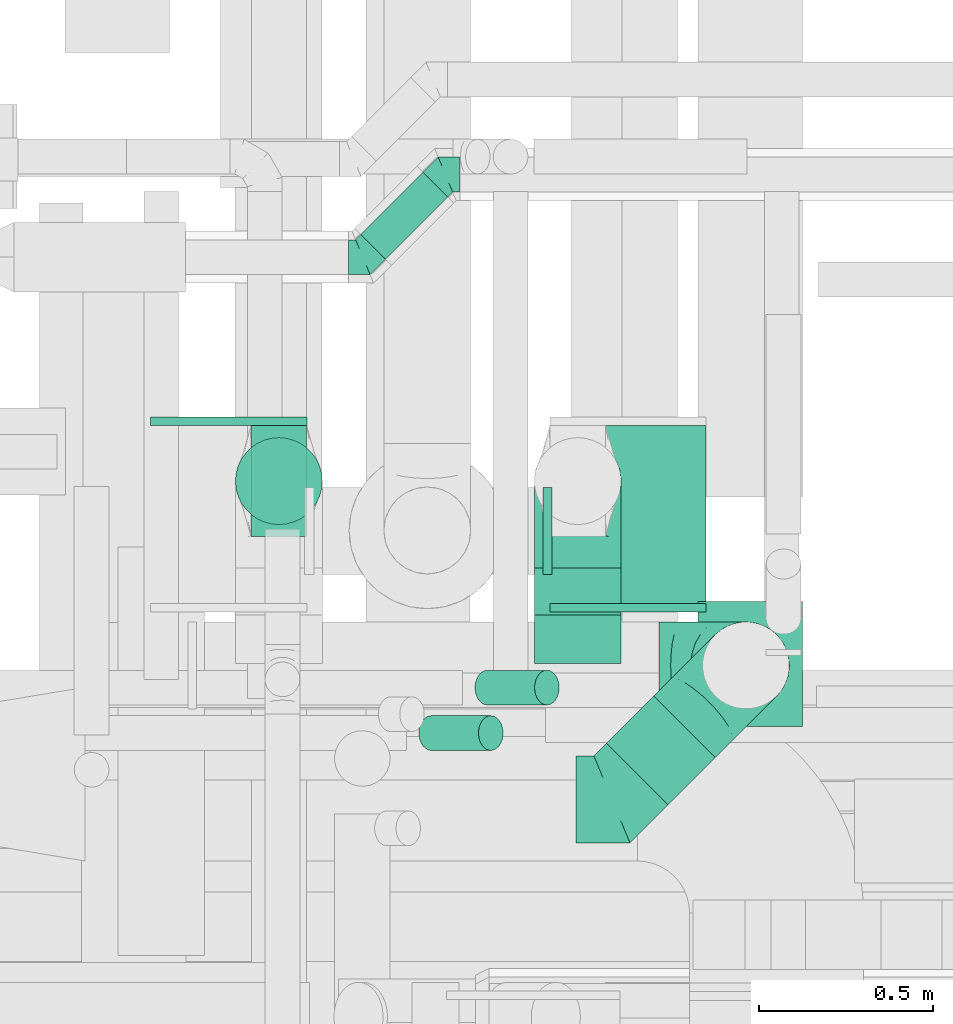
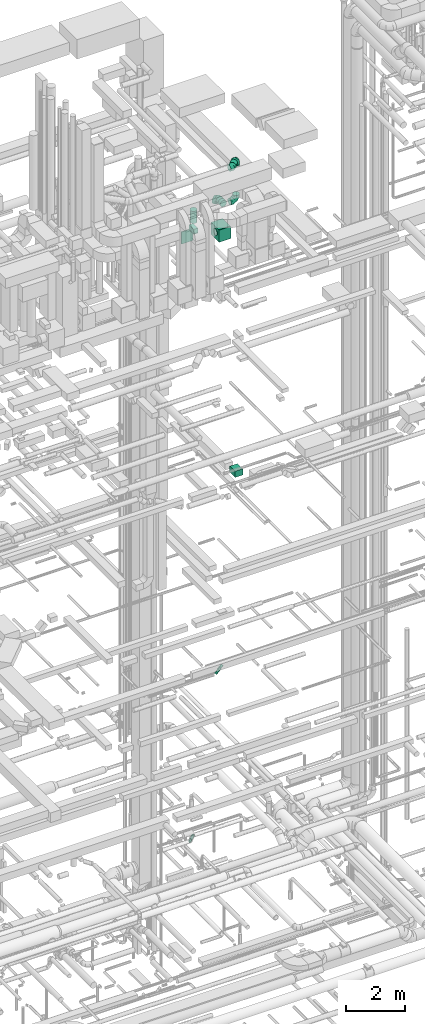
# One storey, part 242 of 337: 11 flow fittings, 9 flow segments.
"""IFC2X3 building model written with IfcOpenShell, lengths in millimetres."""

from ifc_helpers import new_model, entity, si_unit, converted_unit, derived_unit, direction, frame, origin, origin_2d_with_axis, place, context, subcontext, project, spatial, rectangle, circle, extrude, faceted_brep, source, transform, mapped, material, type_object, type_shapes, element, save


model = new_model("IFC2X3")

# Units and contexts
model_context = context("Model", 3, precision=0.01, world=origin(), true_north=direction((6.12303176911189e-17, 1.0)))
body_context = subcontext(model_context, "Body", "Model", "MODEL_VIEW")
ifc_project = project(units=[si_unit("LENGTHUNIT", "METRE", prefix="MILLI"), si_unit("AREAUNIT", "SQUARE_METRE"), si_unit("VOLUMEUNIT", "CUBIC_METRE"), converted_unit("PLANEANGLEUNIT", "DEGREE", entity("IfcRatioMeasure", 0.0174532925199433), si_unit("PLANEANGLEUNIT", "RADIAN"), dimensions=[0, 0, 0, 0, 0, 0, 0]), si_unit("MASSUNIT", "GRAM", prefix="KILO"), derived_unit("MASSDENSITYUNIT", [(si_unit("MASSUNIT", "GRAM", prefix="KILO"), 1), (si_unit("LENGTHUNIT", "METRE"), -3)]), derived_unit("MOMENTOFINERTIAUNIT", [(si_unit("LENGTHUNIT", "METRE"), 4)]), si_unit("TIMEUNIT", "SECOND"), si_unit("FREQUENCYUNIT", "HERTZ"), si_unit("THERMODYNAMICTEMPERATUREUNIT", "DEGREE_CELSIUS"), derived_unit("THERMALTRANSMITTANCEUNIT", [(si_unit("MASSUNIT", "GRAM", prefix="KILO"), 1), (si_unit("THERMODYNAMICTEMPERATUREUNIT", "KELVIN"), -1), (si_unit("TIMEUNIT", "SECOND"), -3)]), derived_unit("VOLUMETRICFLOWRATEUNIT", [(si_unit("LENGTHUNIT", "METRE"), 3), (si_unit("TIMEUNIT", "SECOND"), -1)]), derived_unit("MASSFLOWRATEUNIT", [(si_unit("MASSUNIT", "GRAM", prefix="KILO"), 1), (si_unit("TIMEUNIT", "SECOND"), -1)]), derived_unit("ROTATIONALFREQUENCYUNIT", [(si_unit("TIMEUNIT", "SECOND"), -1)]), si_unit("ELECTRICCURRENTUNIT", "AMPERE"), si_unit("ELECTRICVOLTAGEUNIT", "VOLT"), si_unit("POWERUNIT", "WATT"), si_unit("FORCEUNIT", "NEWTON", prefix="KILO"), si_unit("ILLUMINANCEUNIT", "LUX"), si_unit("LUMINOUSFLUXUNIT", "LUMEN"), si_unit("LUMINOUSINTENSITYUNIT", "CANDELA"), derived_unit("USERDEFINED", [(si_unit("MASSUNIT", "GRAM", prefix="KILO"), -1), (si_unit("LENGTHUNIT", "METRE"), -2), (si_unit("TIMEUNIT", "SECOND"), 3), (si_unit("LUMINOUSFLUXUNIT", "LUMEN"), 1)]), derived_unit("LINEARVELOCITYUNIT", [(si_unit("LENGTHUNIT", "METRE"), 1), (si_unit("TIMEUNIT", "SECOND"), -1)]), si_unit("PRESSUREUNIT", "PASCAL"), derived_unit("USERDEFINED", [(si_unit("LENGTHUNIT", "METRE"), -2), (si_unit("MASSUNIT", "GRAM", prefix="KILO"), 1), (si_unit("TIMEUNIT", "SECOND"), -2)]), derived_unit("LINEARFORCEUNIT", [(si_unit("MASSUNIT", "GRAM", prefix="KILO"), 1), (si_unit("LENGTHUNIT", "METRE"), 1), (si_unit("TIMEUNIT", "SECOND"), -2), (si_unit("LENGTHUNIT", "METRE"), -1)]), derived_unit("PLANARFORCEUNIT", [(si_unit("MASSUNIT", "GRAM", prefix="KILO"), 1), (si_unit("LENGTHUNIT", "METRE"), 1), (si_unit("TIMEUNIT", "SECOND"), -2), (si_unit("LENGTHUNIT", "METRE"), -2)])], contexts=[model_context])

# Site, building, storey
site_placement = place(None, origin())
site = spatial("IfcSite", under=ifc_project, at=site_placement, CompositionType="ELEMENT")
building_placement = place(site_placement, origin())
building = spatial("IfcBuilding", under=site, at=building_placement, CompositionType="ELEMENT")
storey_placement = place(building_placement, origin())
storey = spatial("IfcBuildingStorey", under=building, at=storey_placement, CompositionType="ELEMENT", Elevation=0.0)

# Flow segments
duct_segment_type_1 = type_object("IfcDuctSegmentType", PredefinedType="NOTDEFINED")
flow_segment_1_placement = place(storey_placement, frame((61894.65, 10174.07, 18850.0)))
element("IfcFlowSegment", 1, at=flow_segment_1_placement, inside=storey, type_object=duct_segment_type_1, context=body_context, shape_type="SweptSolid", body=[
    extrude(rectangle(XDim=360.158729652658, YDim=300.000000000001, at=origin_2d_with_axis()), frame((150.0, 180.08, 0.0), z_axis=(0.0, 0.0, 1.0), x_axis=(0.0, 1.0, 0.0)), (0.0, 0.0, 1.0), 249.999999999999),
])
flow_segment_2_placement = place(storey_placement, frame((61467.66, 10528.49, 28450.0)))
element("IfcFlowSegment", 2, at=flow_segment_2_placement, inside=storey, type_object=duct_segment_type_1, context=body_context, shape_type="SweptSolid", body=[
    extrude(rectangle(XDim=512.000000000001, YDim=450.000000000002, at=origin_2d_with_axis()), frame((225.0, 256.0, 0.0), z_axis=(0.0, 0.0, 1.0), x_axis=(0.0, 1.0, 0.0)), (0.0, 0.0, 1.0), 499.999999999999),
])
flow_segment_3_placement = place(storey_placement, frame((60608.16, 10720.49, 28970.0)))
element("IfcFlowSegment", 3, at=flow_segment_3_placement, inside=storey, type_object=duct_segment_type_1, context=body_context, shape_type="SweptSolid", body=[
    extrude(rectangle(XDim=320.000000000003, YDim=159.999999999998, at=origin_2d_with_axis()), frame((80.0, 160.0, 0.0), z_axis=(0.0, 0.0, 1.0), x_axis=(0.0, -1.0, 0.0)), (0.0, 0.0, 1.0), 180.000000000002),
])
duct_segment_type_2 = type_object("IfcDuctSegmentType", PredefinedType="NOTDEFINED")
flow_segment_4_placement = place(storey_placement, frame((60922.1, 11517.23, 3398.4)))
element("IfcFlowSegment", 4, at=flow_segment_4_placement, inside=storey, type_object=duct_segment_type_2, context=body_context, shape_type="SweptSolid", body=[
    extrude(circle(Radius=50.0, at=origin_2d_with_axis()), frame((36.95, 36.95, 51.6), z_axis=(0.707106781186415, 0.70710678118668, 0.0), x_axis=(0.70710678118668, -0.707106781186415, 0.0)), (0.0, 0.0, 1.0), 253.309524416838),
])
flow_segment_5_placement = place(storey_placement, frame((61250.98, 10234.73, 11042.34)))
element("IfcFlowSegment", 5, at=flow_segment_5_placement, inside=storey, type_object=duct_segment_type_2, context=body_context, shape_type="SweptSolid", body=[
    extrude(circle(Radius=50.0, at=origin_2d_with_axis()), frame((36.95, 51.6, 36.95), z_axis=(0.707106523092446, 0.0, 0.707107039280555), x_axis=(0.0, 1.0, 0.0)), (0.0, 0.0, 1.0), 242.426245385358),
])
flow_segment_6_placement = place(storey_placement, frame((61089.62, 10104.0, 11042.34)))
element("IfcFlowSegment", 6, at=flow_segment_6_placement, inside=storey, type_object=duct_segment_type_2, context=body_context, shape_type="SweptSolid", body=[
    extrude(circle(Radius=50.0, at=origin_2d_with_axis()), frame((36.95, 51.6, 36.95), z_axis=(0.707106523092436, 0.0, 0.707107039280565), x_axis=(0.0, 1.0, 0.0)), (0.0, 0.0, 1.0), 242.426245385361),
])
flow_segment_7_placement = place(storey_placement, frame((61629.76, 9947.97, 31673.4)))
element("IfcFlowSegment", 7, at=flow_segment_7_placement, inside=storey, type_object=duct_segment_type_2, context=body_context, shape_type="SweptSolid", body=[
    extrude(circle(Radius=125.0, at=origin_2d_with_axis()), frame((89.98, 89.98, 126.6), z_axis=(0.707106781186559, 0.707106781186536, 0.0), x_axis=(0.707106781186536, -0.707106781186559, 0.0)), (0.0, 0.0, 1.0), 191.560539722336),
])
flow_segment_8_placement = place(storey_placement, frame((61421.56, 10495.19, 29973.4)))
element("IfcFlowSegment", 8, at=flow_segment_8_placement, inside=storey, type_object=duct_segment_type_2, context=body_context, shape_type="SweptSolid", body=[
    extrude(circle(Radius=125.0, at=origin_2d_with_axis()), frame((126.6, 0.0, 126.6), z_axis=(0.0, 1.0, 0.0), x_axis=(1.0, 0.0, 0.0)), (0.0, 0.0, 1.0), 135.302523354552),
])
flow_segment_9_placement = place(storey_placement, frame((60561.56, 10753.89, 29350.0)))
element("IfcFlowSegment", 9, at=flow_segment_9_placement, inside=storey, type_object=duct_segment_type_2, context=body_context, shape_type="SweptSolid", body=[
    extrude(circle(Radius=125.0, at=origin_2d_with_axis()), frame((126.6, 126.6, 0.0), z_axis=(0.0, 0.0, 1.0), x_axis=(-1.0, 0.0, 0.0)), (0.0, 0.0, 1.0), 500.000000000008),
])

# Flow fittings
ifc_material = material()
duct_fitting_type_1 = type_object("IfcDuctFittingType", PredefinedType="NOTDEFINED", material=ifc_material)
shared_shape_1 = source(origin(), body_context, "Body", "SweptSolid", [
    extrude(rectangle(XDim=24.9999999999999, YDim=450.0, at=origin_2d_with_axis()), frame((12.5, 0.0, -250.0)), (0.0, 0.0, 1.0), 500.0),
])
type_shapes(duct_fitting_type_1, [shared_shape_1])
for number, where, z_axis, x_axis in (
    (10, (61692.66, 10528.49, 28700.0), (0.0, 0.0, 1.0), (0.0, -1.0, 0.0)),
    (11, (60543.66, 11040.49, 28700.0), (0.0, 0.0, 1.0), (0.0, 1.0, 0.0)),
):
    element("IfcFlowFitting", number, at=place(storey_placement, frame(where, z_axis=z_axis, x_axis=x_axis)), inside=storey, type_object=duct_fitting_type_1, material=ifc_material, context=body_context, shape_type="MappedRepresentation", body=[
        mapped(shared_shape_1, transform((0.0, 0.0, 0.0), scale=1.0)),
    ])
duct_fitting_type_2 = type_object("IfcDuctFittingType", PredefinedType="NOTDEFINED", material=ifc_material)
shared_shape_2 = source(origin(), body_context, "Body", "SweptSolid", [
    extrude(rectangle(XDim=160.0, YDim=26.096, at=origin_2d_with_axis()), frame((6.95, 0.0, -160.0), z_axis=(0.0, 0.0, 1.0), x_axis=(0.0, -1.0, 0.0)), (0.0, 0.0, 1.0), 320.0),
])
type_shapes(duct_fitting_type_2, [shared_shape_2])
flow_fitting_1_placement = place(storey_placement, frame((60688.16, 10880.49, 28950.0), z_axis=(0.0, -1.0, 0.0), x_axis=(0.0, 0.0, 1.0)))
element("IfcFlowFitting", 12, at=flow_fitting_1_placement, inside=storey, type_object=duct_fitting_type_2, material=ifc_material, context=body_context, shape_type="MappedRepresentation", body=[
    mapped(shared_shape_2, transform((0.0, 0.0, 0.0), scale=1.0)),
])
duct_fitting_type_3 = type_object("IfcDuctFittingType", PredefinedType="NOTDEFINED", material=ifc_material)
shared_shape_3 = source(origin(), body_context, "Body", "Brep", [
    faceted_brep([(-250.0, 0.0, -125.0), (-250.0, -32.35, -120.74), (-250.0, -62.5, -108.25), (-250.0, -88.39, -88.39), (-250.0, -108.25, -62.5), (-250.0, -120.74, -32.35), (-250.0, -125.0, 0.0), (-250.0, -120.74, 32.35), (-250.0, -108.25, 62.5), (-250.0, -88.39, 88.39), (-250.0, -62.5, 108.25), (-250.0, -32.35, 120.74), (-250.0, 0.0, 125.0), (-250.0, 32.35, 120.74), (-250.0, 62.5, 108.25), (-250.0, 88.39, 88.39), (-250.0, 108.25, 62.5), (-250.0, 120.74, 32.35), (-250.0, 125.0, 0.0), (-250.0, 120.74, -32.35), (-250.0, 108.25, -62.5), (-250.0, 88.39, -88.39), (-250.0, 62.5, -108.25), (-250.0, 32.35, -120.74), (-191.68, 32.35, 120.74), (-199.76, 62.5, 108.25), (-183.01, 0.0, 125.0), (-206.7, 88.39, 88.39), (-215.37, 120.74, 32.35), (-216.51, 125.0, 0.0), (-212.02, 108.25, 62.5), (-212.02, 108.25, -62.5), (-206.7, 88.39, -88.39), (-215.37, 120.74, -32.35), (-191.68, 32.35, -120.74), (-183.01, 0.0, -125.0), (-199.76, 62.5, -108.25), (-174.34, -32.35, -120.74), (-166.27, -62.5, -108.25), (-159.33, -88.39, -88.39), (-154.01, -108.25, -62.5), (-150.66, -120.74, -32.35), (-149.52, -125.0, 0.0), (-150.66, -120.74, 32.35), (-154.01, -108.25, 62.5), (-159.33, -88.39, 88.39), (-166.27, -62.5, 108.25), (-174.34, -32.35, 120.74), (-90.67, 90.67, 120.74), (-112.74, 112.74, 108.25), (-66.99, 66.99, 125.0), (-131.69, 131.69, 88.39), (-146.23, 146.23, 62.5), (-155.38, 155.38, 32.35), (-158.49, 158.49, 0.0), (-155.38, 155.38, -32.35), (-146.23, 146.23, -62.5), (-131.69, 131.69, -88.39), (-90.67, 90.67, -120.74), (-66.99, 66.99, -125.0), (-112.74, 112.74, -108.25), (-43.3, 43.3, -120.74), (-21.23, 21.23, -108.25), (-2.28, 2.28, -88.39), (12.26, -12.26, -62.5), (21.4, -21.4, -32.35), (24.52, -24.52, 0.0), (21.4, -21.4, 32.35), (12.26, -12.26, 62.5), (-2.28, 2.28, 88.39), (-21.23, 21.23, 108.25), (-43.3, 43.3, 120.74), (-32.35, 191.68, 120.74), (-62.5, 199.76, 108.25), (0.0, 183.01, 125.0), (-88.39, 206.7, 88.39), (-108.25, 212.02, 62.5), (-120.74, 215.37, 32.35), (-125.0, 216.51, 0.0), (-120.74, 215.37, -32.35), (-108.25, 212.02, -62.5), (-88.39, 206.7, -88.39), (-32.35, 191.68, -120.74), (0.0, 183.01, -125.0), (-62.5, 199.76, -108.25), (32.35, 174.34, -120.74), (62.5, 166.27, -108.25), (88.39, 159.33, -88.39), (108.25, 154.01, -62.5), (120.74, 150.66, -32.35), (125.0, 149.52, 0.0), (120.74, 150.66, 32.35), (108.25, 154.01, 62.5), (88.39, 159.33, 88.39), (62.5, 166.27, 108.25), (32.35, 174.34, 120.74), (-32.35, 250.0, -120.74), (-62.5, 250.0, -108.25), (-88.39, 250.0, -88.39), (-108.25, 250.0, -62.5), (-120.74, 250.0, -32.35), (-125.0, 250.0, 0.0), (-120.74, 250.0, 32.35), (-108.25, 250.0, 62.5), (-88.39, 250.0, 88.39), (-62.5, 250.0, 108.25), (-32.35, 250.0, 120.74), (0.0, 250.0, 125.0), (32.35, 250.0, 120.74), (62.5, 250.0, 108.25), (88.39, 250.0, 88.39), (108.25, 250.0, 62.5), (120.74, 250.0, 32.35), (125.0, 250.0, 0.0), (120.74, 250.0, -32.35), (108.25, 250.0, -62.5), (88.39, 250.0, -88.39), (62.5, 250.0, -108.25), (32.35, 250.0, -120.74), (0.0, 250.0, -125.0)], [[[0, 1, 2, 3, 4, 5, 6, 7, 8, 9, 10, 11, 12, 13, 14, 15, 16, 17, 18, 19, 20, 21, 22, 23]], [[24, 25, 14, 13]], [[26, 24, 13, 12]], [[14, 25, 27, 15]], [[28, 29, 18, 17]], [[30, 28, 17, 16]], [[15, 27, 30, 16]], [[20, 31, 32, 21]], [[33, 31, 20, 19]], [[18, 29, 33, 19]], [[34, 35, 0, 23]], [[36, 34, 23, 22]], [[21, 32, 36, 22]], [[1, 0, 35, 37]], [[2, 1, 37, 38]], [[38, 39, 3, 2]], [[5, 4, 40, 41]], [[6, 5, 41, 42]], [[39, 40, 4, 3]], [[6, 42, 43, 7]], [[7, 43, 44, 8]], [[8, 44, 45, 9]], [[9, 45, 46, 10]], [[10, 46, 47, 11]], [[26, 12, 11, 47]], [[48, 49, 25, 24]], [[50, 48, 24, 26]], [[27, 25, 49, 51]], [[52, 53, 28, 30]], [[51, 52, 30, 27]], [[29, 28, 53, 54]], [[55, 56, 31, 33]], [[54, 55, 33, 29]], [[32, 31, 56, 57]], [[58, 59, 35, 34]], [[60, 58, 34, 36]], [[57, 60, 36, 32]], [[37, 35, 59, 61]], [[38, 37, 61, 62]], [[39, 38, 62, 63]], [[41, 40, 64, 65]], [[42, 41, 65, 66]], [[63, 64, 40, 39]], [[43, 42, 66, 67]], [[44, 43, 67, 68]], [[68, 69, 45, 44]], [[46, 45, 69, 70]], [[47, 46, 70, 71]], [[26, 47, 71, 50]], [[72, 73, 49, 48]], [[74, 72, 48, 50]], [[51, 49, 73, 75]], [[76, 77, 53, 52]], [[75, 76, 52, 51]], [[54, 53, 77, 78]], [[79, 80, 56, 55]], [[78, 79, 55, 54]], [[57, 56, 80, 81]], [[82, 83, 59, 58]], [[84, 82, 58, 60]], [[81, 84, 60, 57]], [[61, 59, 83, 85]], [[62, 61, 85, 86]], [[63, 62, 86, 87]], [[65, 64, 88, 89]], [[66, 65, 89, 90]], [[87, 88, 64, 63]], [[67, 66, 90, 91]], [[68, 67, 91, 92]], [[92, 93, 69, 68]], [[70, 69, 93, 94]], [[71, 70, 94, 95]], [[50, 71, 95, 74]], [[96, 97, 98, 99, 100, 101, 102, 103, 104, 105, 106, 107, 108, 109, 110, 111, 112, 113, 114, 115, 116, 117, 118, 119]], [[72, 74, 107, 106]], [[73, 72, 106, 105]], [[75, 73, 105, 104]], [[77, 76, 103, 102]], [[78, 77, 102, 101]], [[75, 104, 103, 76]], [[78, 101, 100, 79]], [[79, 100, 99, 80]], [[80, 99, 98, 81]], [[84, 97, 96, 82]], [[82, 96, 119, 83]], [[84, 81, 98, 97]], [[83, 119, 118, 85]], [[85, 118, 117, 86]], [[116, 87, 86, 117]], [[88, 115, 114, 89]], [[89, 114, 113, 90]], [[115, 88, 87, 116]], [[91, 90, 113, 112]], [[92, 91, 112, 111]], [[111, 110, 93, 92]], [[95, 94, 109, 108]], [[74, 95, 108, 107]], [[110, 109, 94, 93]]]),
])
type_shapes(duct_fitting_type_3, [shared_shape_3])
for number, where, z_axis, x_axis in (
    (13, (62031.97, 10350.19, 31800.0), (-0.707106781186555, 0.70710678118654, 0.0), (0.70710678118654, 0.707106781186555, 0.0)),
    (14, (62031.97, 10350.19, 30100.0), (0.0, 1.0, 0.0), (0.0, 0.0, -1.0)),
    (15, (61548.16, 10880.49, 30100.0), (-1.0, 0.0, 0.0), (0.0, 1.0, 0.0)),
):
    element("IfcFlowFitting", number, at=place(storey_placement, frame(where, z_axis=z_axis, x_axis=x_axis)), inside=storey, type_object=duct_fitting_type_3, material=ifc_material, context=body_context, shape_type="MappedRepresentation", body=[
        mapped(shared_shape_3, transform((0.0, 0.0, 0.0), scale=1.0)),
    ])
duct_fitting_type_4 = type_object("IfcDuctFittingType", PredefinedType="NOTDEFINED", material=ifc_material)
shared_shape_4 = source(origin(), body_context, "Body", "Brep", [
    faceted_brep([(20.0, 32.35, -120.74), (20.0, 62.5, -108.25), (20.0, 88.39, -88.39), (20.0, 108.25, -62.5), (20.0, 120.74, -32.35), (20.0, 125.0, 0.0), (20.0, 120.74, 32.35), (20.0, 108.25, 62.5), (20.0, 88.39, 88.39), (20.0, 62.5, 108.25), (20.0, 32.35, 120.74), (20.0, 0.0, 125.0), (20.0, -32.35, 120.74), (20.0, -62.5, 108.25), (20.0, -88.39, 88.39), (20.0, -108.25, 62.5), (20.0, -120.74, 32.35), (20.0, -125.0, 0.0), (20.0, -120.74, -32.35), (20.0, -108.25, -62.5), (20.0, -88.39, -88.39), (20.0, -62.5, -108.25), (20.0, -32.35, -120.74), (20.0, 0.0, -125.0), (0.0, 0.0, 125.0), (0.0, 32.35, 120.74), (-6.1, 32.35, 120.74), (-6.1, 0.0, 125.0), (0.0, 62.5, 108.25), (-6.1, 62.5, 108.25), (0.0, 88.39, 88.39), (-6.1, 88.39, 88.39), (0.0, 108.25, 62.5), (0.0, 120.74, 32.35), (-6.1, 120.74, 32.35), (-6.1, 108.25, 62.5), (0.0, 125.0, 0.0), (-6.1, 125.0, 0.0), (0.0, 120.74, -32.35), (-6.1, 120.74, -32.35), (0.0, 108.25, -62.5), (-6.1, 108.25, -62.5), (0.0, 88.39, -88.39), (-6.1, 88.39, -88.39), (0.0, 62.5, -108.25), (0.0, 32.35, -120.74), (-6.1, 32.35, -120.74), (-6.1, 62.5, -108.25), (0.0, 0.0, -125.0), (-6.1, 0.0, -125.0), (0.0, -32.35, -120.74), (-6.1, -32.35, -120.74), (0.0, -62.5, -108.25), (-6.1, -62.5, -108.25), (0.0, -88.39, -88.39), (-6.1, -88.39, -88.39), (0.0, -108.25, -62.5), (0.0, -120.74, -32.35), (-6.1, -120.74, -32.35), (-6.1, -108.25, -62.5), (0.0, -125.0, 0.0), (-6.1, -125.0, 0.0), (0.0, -120.74, 32.35), (-6.1, -120.74, 32.35), (0.0, -108.25, 62.5), (-6.1, -108.25, 62.5), (0.0, -88.39, 88.39), (-6.1, -88.39, 88.39), (0.0, -62.5, 108.25), (0.0, -32.35, 120.74), (-6.1, -32.35, 120.74), (-6.1, -62.5, 108.25)], [[[0, 1, 2, 3, 4, 5, 6, 7, 8, 9, 10, 11, 12, 13, 14, 15, 16, 17, 18, 19, 20, 21, 22, 23]], [[24, 11, 10, 25, 26, 27]], [[25, 10, 9, 28, 29, 26]], [[28, 9, 8, 30, 31, 29]], [[32, 7, 6, 33, 34, 35]], [[33, 6, 5, 36, 37, 34]], [[30, 8, 7, 32, 35, 31]], [[36, 5, 4, 38, 39, 37]], [[38, 4, 3, 40, 41, 39]], [[40, 3, 2, 42, 43, 41]], [[44, 1, 0, 45, 46, 47]], [[45, 0, 23, 48, 49, 46]], [[42, 2, 1, 44, 47, 43]], [[48, 23, 22, 50, 51, 49]], [[50, 22, 21, 52, 53, 51]], [[52, 21, 20, 54, 55, 53]], [[56, 19, 18, 57, 58, 59]], [[57, 18, 17, 60, 61, 58]], [[54, 20, 19, 56, 59, 55]], [[60, 17, 16, 62, 63, 61]], [[62, 16, 15, 64, 65, 63]], [[64, 15, 14, 66, 67, 65]], [[68, 13, 12, 69, 70, 71]], [[69, 12, 11, 24, 27, 70]], [[66, 14, 13, 68, 71, 67]], [[49, 51, 53, 55, 59, 58, 61, 63, 65, 67, 71, 70, 27, 26, 29, 31, 35, 34, 37, 39, 41, 43, 47, 46]]]),
])
type_shapes(duct_fitting_type_4, [shared_shape_4])
flow_fitting_2_placement = place(storey_placement, frame((61467.66, 10737.49, 28740.0), z_axis=(0.0, 0.0, -1.0), x_axis=(-1.0, 0.0, 0.0)))
element("IfcFlowFitting", 16, at=flow_fitting_2_placement, inside=storey, type_object=duct_fitting_type_4, material=ifc_material, context=body_context, shape_type="MappedRepresentation", body=[
    mapped(shared_shape_4, transform((0.0, 0.0, 0.0), scale=1.0)),
])
duct_fitting_type_5 = type_object("IfcDuctFittingType", PredefinedType="NOTDEFINED", material=ifc_material)
shared_shape_5 = source(origin(), body_context, "Body", "Brep", [
    faceted_brep([(-41.42, 0.0, -50.0), (-41.42, -12.94, -48.3), (-41.42, -25.0, -43.3), (-41.42, -35.36, -35.36), (-41.42, -43.3, -25.0), (-41.42, -48.3, -12.94), (-41.42, -50.0, 0.0), (-41.42, -48.3, 12.94), (-41.42, -43.3, 25.0), (-41.42, -35.36, 35.36), (-41.42, -25.0, 43.3), (-41.42, -12.94, 48.3), (-41.42, 0.0, 50.0), (-41.42, 12.94, 48.3), (-41.42, 25.0, 43.3), (-41.42, 35.36, 35.36), (-41.42, 43.3, 25.0), (-41.42, 48.3, 12.94), (-41.42, 50.0, 0.0), (-41.42, 48.3, -12.94), (-41.42, 43.3, -25.0), (-41.42, 35.36, -35.36), (-41.42, 25.0, -43.3), (-41.42, 12.94, -48.3), (-5.36, 12.94, 48.3), (-10.36, 25.0, 43.3), (0.0, 0.0, 50.0), (-14.64, 35.36, 35.36), (-20.0, 48.3, 12.94), (-20.71, 50.0, 0.0), (-17.94, 43.3, 25.0), (-17.94, 43.3, -25.0), (-14.64, 35.36, -35.36), (-20.0, 48.3, -12.94), (-5.36, 12.94, -48.3), (0.0, 0.0, -50.0), (-10.36, 25.0, -43.3), (5.36, -12.94, -48.3), (10.36, -25.0, -43.3), (14.64, -35.36, -35.36), (17.94, -43.3, -25.0), (20.0, -48.3, -12.94), (20.71, -50.0, 0.0), (20.0, -48.3, 12.94), (17.94, -43.3, 25.0), (14.64, -35.36, 35.36), (10.36, -25.0, 43.3), (5.36, -12.94, 48.3), (29.29, 29.29, 50.0), (20.14, 38.44, 48.3), (11.61, 46.97, 43.3), (4.29, 54.29, 35.36), (-1.33, 59.91, 25.0), (-4.86, 63.44, 12.94), (-6.07, 64.64, 0.0), (-4.86, 63.44, -12.94), (-1.33, 59.91, -25.0), (4.29, 54.29, -35.36), (11.61, 46.97, -43.3), (20.14, 38.44, -48.3), (29.29, 29.29, -50.0), (38.44, 20.14, -48.3), (46.97, 11.61, -43.3), (54.29, 4.29, -35.36), (59.91, -1.33, -25.0), (63.44, -4.86, -12.94), (64.64, -6.07, 0.0), (63.44, -4.86, 12.94), (59.91, -1.33, 25.0), (54.29, 4.29, 35.36), (46.97, 11.61, 43.3), (38.44, 20.14, 48.3)], [[[0, 1, 2, 3, 4, 5, 6, 7, 8, 9, 10, 11, 12, 13, 14, 15, 16, 17, 18, 19, 20, 21, 22, 23]], [[24, 25, 14, 13]], [[26, 24, 13, 12]], [[14, 25, 27, 15]], [[28, 29, 18, 17]], [[30, 28, 17, 16]], [[16, 15, 27, 30]], [[20, 31, 32, 21]], [[33, 31, 20, 19]], [[18, 29, 33, 19]], [[34, 35, 0, 23]], [[36, 34, 23, 22]], [[32, 36, 22, 21]], [[1, 0, 35, 37]], [[2, 1, 37, 38]], [[38, 39, 3, 2]], [[5, 4, 40, 41]], [[6, 5, 41, 42]], [[39, 40, 4, 3]], [[6, 42, 43, 7]], [[7, 43, 44, 8]], [[8, 44, 45, 9]], [[9, 45, 46, 10]], [[10, 46, 47, 11]], [[26, 12, 11, 47]], [[24, 26, 48, 49]], [[25, 24, 49, 50]], [[27, 25, 50, 51]], [[28, 30, 52, 53]], [[29, 28, 53, 54]], [[27, 51, 52, 30]], [[29, 54, 55, 33]], [[33, 55, 56, 31]], [[31, 56, 57, 32]], [[36, 58, 59, 34]], [[34, 59, 60, 35]], [[36, 32, 57, 58]], [[61, 62, 38, 37]], [[60, 61, 37, 35]], [[63, 39, 38, 62]], [[40, 64, 65, 41]], [[41, 65, 66, 42]], [[64, 40, 39, 63]], [[43, 42, 66, 67]], [[44, 43, 67, 68]], [[68, 69, 45, 44]], [[47, 46, 70, 71]], [[26, 47, 71, 48]], [[69, 70, 46, 45]], [[59, 58, 57, 56, 55, 54, 53, 52, 51, 50, 49, 48, 71, 70, 69, 68, 67, 66, 65, 64, 63, 62, 61, 60]]]),
])
type_shapes(duct_fitting_type_5, [shared_shape_5])
flow_fitting_3_placement = place(storey_placement, frame((60929.76, 11524.89, 3450.0)))
element("IfcFlowFitting", 17, at=flow_fitting_3_placement, inside=storey, type_object=duct_fitting_type_5, material=ifc_material, context=body_context, shape_type="MappedRepresentation", body=[
    mapped(shared_shape_5, transform((0.0, 0.0, 0.0), scale=1.0)),
])
flow_fitting_4_placement = place(storey_placement, frame((61167.45, 11762.59, 3450.0), z_axis=(0.0, 0.0, 1.0), x_axis=(-1.0, 0.0, 0.0)))
element("IfcFlowFitting", 18, at=flow_fitting_4_placement, inside=storey, type_object=duct_fitting_type_5, material=ifc_material, context=body_context, shape_type="MappedRepresentation", body=[
    mapped(shared_shape_5, transform((0.0, 0.0, 0.0), scale=1.0)),
])
duct_fitting_type_6 = type_object("IfcDuctFittingType", PredefinedType="NOTDEFINED", material=ifc_material)
shared_shape_6 = source(origin(), body_context, "Body", "Brep", [
    faceted_brep([(-103.55, 0.0, -125.0), (-103.55, -32.35, -120.74), (-103.55, -62.5, -108.25), (-103.55, -88.39, -88.39), (-103.55, -108.25, -62.5), (-103.55, -120.74, -32.35), (-103.55, -125.0, 0.0), (-103.55, -120.74, 32.35), (-103.55, -108.25, 62.5), (-103.55, -88.39, 88.39), (-103.55, -62.5, 108.25), (-103.55, -32.35, 120.74), (-103.55, 0.0, 125.0), (-103.55, 32.35, 120.74), (-103.55, 62.5, 108.25), (-103.55, 88.39, 88.39), (-103.55, 108.25, 62.5), (-103.55, 120.74, 32.35), (-103.55, 125.0, 0.0), (-103.55, 120.74, -32.35), (-103.55, 108.25, -62.5), (-103.55, 88.39, -88.39), (-103.55, 62.5, -108.25), (-103.55, 32.35, -120.74), (-13.4, 32.35, 120.74), (-25.89, 62.5, 108.25), (0.0, 0.0, 125.0), (-36.61, 88.39, 88.39), (-44.84, 108.25, 62.5), (-50.01, 120.74, 32.35), (-51.78, 125.0, 0.0), (-50.01, 120.74, -32.35), (-44.84, 108.25, -62.5), (-36.61, 88.39, -88.39), (-13.4, 32.35, -120.74), (0.0, 0.0, -125.0), (-25.89, 62.5, -108.25), (13.4, -32.35, -120.74), (25.89, -62.5, -108.25), (36.61, -88.39, -88.39), (44.84, -108.25, -62.5), (50.01, -120.74, -32.35), (51.78, -125.0, 0.0), (50.01, -120.74, 32.35), (44.84, -108.25, 62.5), (36.61, -88.39, 88.39), (25.89, -62.5, 108.25), (13.4, -32.35, 120.74), (73.22, 73.22, 125.0), (50.35, 96.1, 120.74), (29.03, 117.42, 108.25), (10.72, 135.72, 88.39), (-3.32, 149.77, 62.5), (-12.15, 158.6, 32.35), (-15.17, 161.61, 0.0), (-12.15, 158.6, -32.35), (-3.32, 149.77, -62.5), (10.72, 135.72, -88.39), (29.03, 117.42, -108.25), (50.35, 96.1, -120.74), (73.22, 73.22, -125.0), (96.1, 50.35, -120.74), (117.42, 29.03, -108.25), (135.72, 10.72, -88.39), (149.77, -3.32, -62.5), (158.6, -12.15, -32.35), (161.61, -15.17, 0.0), (158.6, -12.15, 32.35), (149.77, -3.32, 62.5), (135.72, 10.72, 88.39), (117.42, 29.03, 108.25), (96.1, 50.35, 120.74)], [[[0, 1, 2, 3, 4, 5, 6, 7, 8, 9, 10, 11, 12, 13, 14, 15, 16, 17, 18, 19, 20, 21, 22, 23]], [[24, 25, 14, 13]], [[26, 24, 13, 12]], [[14, 25, 27, 15]], [[28, 29, 17, 16]], [[28, 16, 15, 27]], [[30, 18, 17, 29]], [[31, 32, 20, 19]], [[30, 31, 19, 18]], [[32, 33, 21, 20]], [[34, 35, 0, 23]], [[36, 34, 23, 22]], [[33, 36, 22, 21]], [[1, 0, 35, 37]], [[2, 1, 37, 38]], [[38, 39, 3, 2]], [[5, 4, 40, 41]], [[6, 5, 41, 42]], [[39, 40, 4, 3]], [[6, 42, 43, 7]], [[7, 43, 44, 8]], [[8, 44, 45, 9]], [[9, 45, 46, 10]], [[10, 46, 47, 11]], [[26, 12, 11, 47]], [[24, 26, 48, 49]], [[25, 24, 49, 50]], [[27, 25, 50, 51]], [[29, 28, 52, 53]], [[30, 29, 53, 54]], [[51, 52, 28, 27]], [[30, 54, 55, 31]], [[31, 55, 56, 32]], [[57, 33, 32, 56]], [[36, 58, 59, 34]], [[34, 59, 60, 35]], [[58, 36, 33, 57]], [[35, 60, 61, 37]], [[37, 61, 62, 38]], [[63, 39, 38, 62]], [[40, 64, 65, 41]], [[41, 65, 66, 42]], [[64, 40, 39, 63]], [[43, 42, 66, 67]], [[44, 43, 67, 68]], [[68, 69, 45, 44]], [[47, 46, 70, 71]], [[26, 47, 71, 48]], [[69, 70, 46, 45]], [[59, 58, 57, 56, 55, 54, 53, 52, 51, 50, 49, 48, 71, 70, 69, 68, 67, 66, 65, 64, 63, 62, 61, 60]]]),
])
type_shapes(duct_fitting_type_6, [shared_shape_6])
flow_fitting_5_placement = place(storey_placement, frame((61646.52, 9964.73, 31800.0)))
element("IfcFlowFitting", 19, at=flow_fitting_5_placement, inside=storey, type_object=duct_fitting_type_6, material=ifc_material, context=body_context, shape_type="MappedRepresentation", body=[
    mapped(shared_shape_6, transform((0.0, 0.0, 0.0), scale=1.0)),
])
duct_fitting_type_7 = type_object("IfcDuctFittingType", PredefinedType="NOTDEFINED", material=ifc_material)
shared_shape_7 = source(origin(), body_context, "Body", "Brep", [
    faceted_brep([(20.0, 32.35, -120.74), (20.0, 62.5, -108.25), (20.0, 88.39, -88.39), (20.0, 108.25, -62.5), (20.0, 120.74, -32.35), (20.0, 125.0, 0.0), (20.0, 120.74, 32.35), (20.0, 108.25, 62.5), (20.0, 88.39, 88.39), (20.0, 62.5, 108.25), (20.0, 32.35, 120.74), (20.0, 0.0, 125.0), (20.0, -32.35, 120.74), (20.0, -62.5, 108.25), (20.0, -88.39, 88.39), (20.0, -108.25, 62.5), (20.0, -120.74, 32.35), (20.0, -125.0, 0.0), (20.0, -120.74, -32.35), (20.0, -108.25, -62.5), (20.0, -88.39, -88.39), (20.0, -62.5, -108.25), (20.0, -32.35, -120.74), (20.0, 0.0, -125.0), (0.0, 0.0, 125.0), (0.0, 32.35, 120.74), (-118.9, 32.35, 120.74), (-118.9, 0.0, 125.0), (0.0, 62.5, 108.25), (-118.9, 62.5, 108.25), (0.0, 88.39, 88.39), (-118.9, 88.39, 88.39), (0.0, 108.25, 62.5), (0.0, 120.74, 32.35), (-118.9, 120.74, 32.35), (-118.9, 108.25, 62.5), (0.0, 125.0, 0.0), (-118.9, 125.0, 0.0), (0.0, 120.74, -32.35), (-118.9, 120.74, -32.35), (0.0, 108.25, -62.5), (-118.9, 108.25, -62.5), (0.0, 88.39, -88.39), (-118.9, 88.39, -88.39), (0.0, 62.5, -108.25), (0.0, 32.35, -120.74), (-118.9, 32.35, -120.74), (-118.9, 62.5, -108.25), (0.0, 0.0, -125.0), (-118.9, 0.0, -125.0), (0.0, -32.35, -120.74), (-118.9, -32.35, -120.74), (0.0, -62.5, -108.25), (-118.9, -62.5, -108.25), (0.0, -88.39, -88.39), (-118.9, -88.39, -88.39), (0.0, -108.25, -62.5), (0.0, -120.74, -32.35), (-118.9, -120.74, -32.35), (-118.9, -108.25, -62.5), (0.0, -125.0, 0.0), (-118.9, -125.0, 0.0), (0.0, -120.74, 32.35), (-118.9, -120.74, 32.35), (0.0, -108.25, 62.5), (-118.9, -108.25, 62.5), (0.0, -88.39, 88.39), (-118.9, -88.39, 88.39), (0.0, -62.5, 108.25), (0.0, -32.35, 120.74), (-118.9, -32.35, 120.74), (-118.9, -62.5, 108.25)], [[[0, 1, 2, 3, 4, 5, 6, 7, 8, 9, 10, 11, 12, 13, 14, 15, 16, 17, 18, 19, 20, 21, 22, 23]], [[24, 11, 10, 25, 26, 27]], [[25, 10, 9, 28, 29, 26]], [[28, 9, 8, 30, 31, 29]], [[32, 7, 6, 33, 34, 35]], [[33, 6, 5, 36, 37, 34]], [[30, 8, 7, 32, 35, 31]], [[36, 5, 4, 38, 39, 37]], [[38, 4, 3, 40, 41, 39]], [[40, 3, 2, 42, 43, 41]], [[44, 1, 0, 45, 46, 47]], [[45, 0, 23, 48, 49, 46]], [[42, 2, 1, 44, 47, 43]], [[48, 23, 22, 50, 51, 49]], [[50, 22, 21, 52, 53, 51]], [[52, 21, 20, 54, 55, 53]], [[56, 19, 18, 57, 58, 59]], [[57, 18, 17, 60, 61, 58]], [[54, 20, 19, 56, 59, 55]], [[60, 17, 16, 62, 63, 61]], [[62, 16, 15, 64, 65, 63]], [[64, 15, 14, 66, 67, 65]], [[68, 13, 12, 69, 70, 71]], [[69, 12, 11, 24, 27, 70]], [[66, 14, 13, 68, 71, 67]], [[49, 51, 53, 55, 59, 58, 61, 63, 65, 67, 71, 70, 27, 26, 29, 31, 35, 34, 37, 39, 41, 43, 47, 46]]]),
])
type_shapes(duct_fitting_type_7, [shared_shape_7])
flow_fitting_6_placement = place(storey_placement, frame((61548.16, 10475.19, 30100.0), z_axis=(0.0, 0.0, -1.0), x_axis=(0.0, 1.0, 0.0)))
element("IfcFlowFitting", 20, at=flow_fitting_6_placement, inside=storey, type_object=duct_fitting_type_7, material=ifc_material, context=body_context, shape_type="MappedRepresentation", body=[
    mapped(shared_shape_7, transform((0.0, 0.0, 0.0), scale=1.0)),
])

save(model, "model.ifc")
